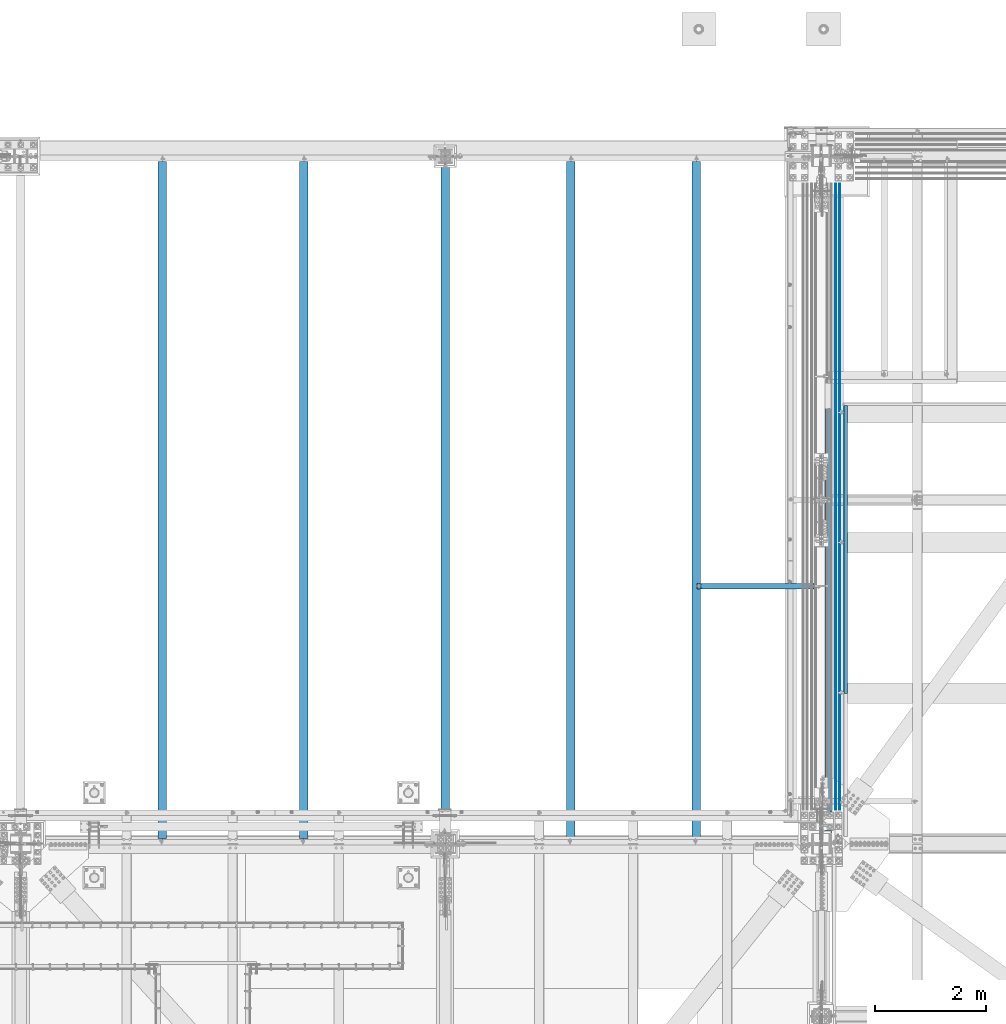
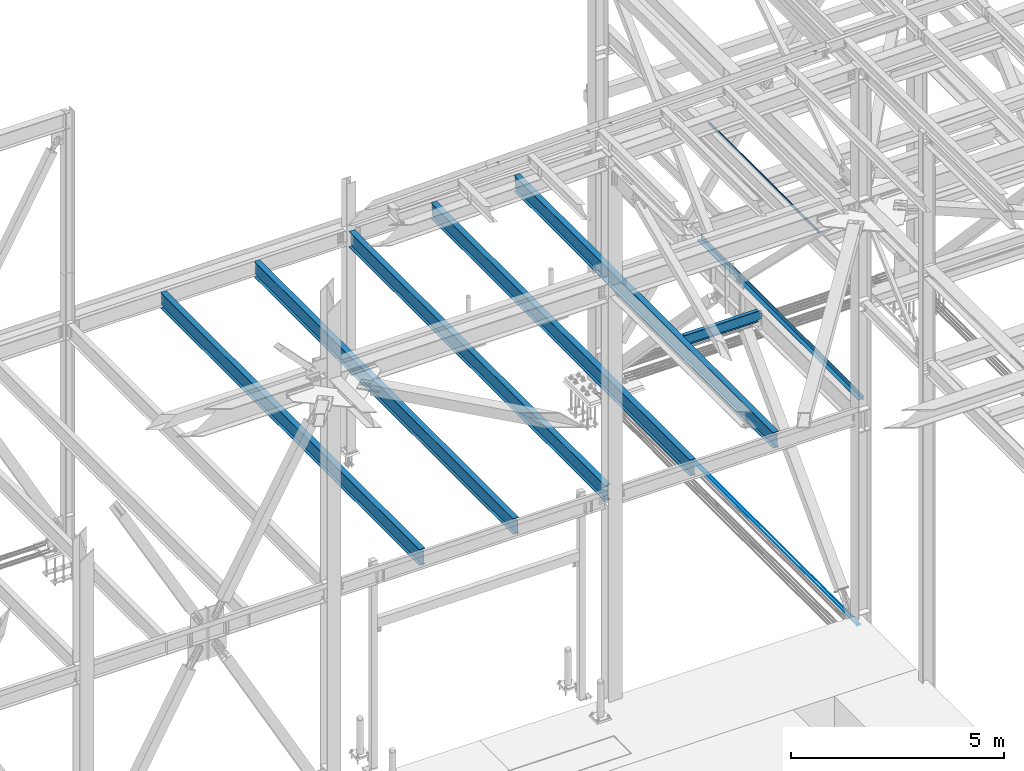
# One storey, part 1937 of 3843: 10 beams, 10 elements without a shape of their own.
"""IFC2X3 building model written with IfcOpenShell, lengths in millimetres."""

from ifc_helpers import new_model, si_unit, frame, origin_with_axes, place, context, subcontext, project, spatial, faceted_brep, material, type_object, element, aggregate, save


model = new_model("IFC2X3")

# Units and contexts
model_context = context("Model", 3, precision=1e-05, world=origin_with_axes())
body_context = subcontext(model_context, "Body", "Model", "MODEL_VIEW")
ifc_project = project(units=[si_unit("LENGTHUNIT", "METRE", prefix="MILLI"), si_unit("AREAUNIT", "SQUARE_METRE"), si_unit("VOLUMEUNIT", "CUBIC_METRE"), si_unit("MASSUNIT", "GRAM", prefix="KILO"), si_unit("TIMEUNIT", "SECOND"), si_unit("PLANEANGLEUNIT", "RADIAN"), si_unit("SOLIDANGLEUNIT", "STERADIAN"), si_unit("THERMODYNAMICTEMPERATUREUNIT", "DEGREE_CELSIUS"), si_unit("LUMINOUSINTENSITYUNIT", "LUMEN")], contexts=[model_context])

# Site, building, storey
site_placement = place(None, origin_with_axes())
site = spatial("IfcSite", under=ifc_project, at=site_placement, CompositionType="ELEMENT")
building_placement = place(site_placement, origin_with_axes())
building = spatial("IfcBuilding", under=site, at=building_placement, Name="Undefined", CompositionType="ELEMENT")
storey_placement = place(building_placement, origin_with_axes())
storey = spatial("IfcBuildingStorey", under=building, at=storey_placement, Name="Undefined", CompositionType="ELEMENT", Elevation=0.0)

# Assembly, beam
assembly_1_placement = place(storey_placement, origin_with_axes())
assembly_1 = element("IfcElementAssembly", 1, at=assembly_1_placement, inside=storey, Name="REBAR", AssemblyPlace="NOTDEFINED", PredefinedType="RIGID_FRAME")
ifc_material_1 = material(Name="STEEL/A706-60")
beam_type_1 = type_object("IfcBeamType", Name="#10 REBAR", PredefinedType="NOTDEFINED")
beam_1_placement = place(assembly_1_placement, frame((77266.8, 104063.800019533, 29700.5375), z_axis=(0.0, 0.0, 1.0), x_axis=(0.0, -1.0, 0.0)))
beam_1 = element("IfcBeam", 2, at=beam_1_placement, type_object=beam_type_1, material=ifc_material_1, Name="REBAR", ObjectType="#10 REBAR", context=body_context, shape_type="Brep", body=[
    faceted_brep([(0.0, -7.9375, 0.0), (0.0, -5.61266007566883, -5.61266007566883), (11239.5874999941, -5.61266007566883, -5.61266007566883), (11239.5874999941, -7.9375, 0.0), (0.0, 0.0, -7.9375), (11239.5874999941, 0.0, -7.9375), (0.0, 5.61266007566883, -5.61266007566883), (11239.5874999941, 5.61266007566883, -5.61266007566883), (0.0, 7.9375, 0.0), (11239.5874999941, 7.9375, 0.0), (0.0, 5.61266007566883, 5.61266007566883), (11239.5874999941, 5.61266007566883, 5.61266007566883), (0.0, 0.0, 7.9375), (11239.5874999941, 0.0, 7.9375), (0.0, -5.61266007566883, 5.61266007566883), (11239.5874999941, -5.61266007566883, 5.61266007566883)], [[[0, 1, 2, 3]], [[1, 4, 5, 2]], [[4, 6, 7, 5]], [[6, 8, 9, 7]], [[8, 10, 11, 9]], [[10, 12, 13, 11]], [[12, 14, 15, 13]], [[14, 0, 3, 15]], [[5, 7, 9, 11, 13, 15, 3, 2]], [[14, 12, 10, 8, 6, 4, 1, 0]]]),
])
aggregate(assembly_1, [beam_1])

assembly_2_placement = place(storey_placement, origin_with_axes())
assembly_2 = element("IfcElementAssembly", 3, at=assembly_2_placement, inside=storey, Name="REBAR", AssemblyPlace="NOTDEFINED", PredefinedType="RIGID_FRAME")
beam_2_placement = place(assembly_2_placement, frame((77343.0, 104063.800019533, 29700.5375), z_axis=(0.0, 0.0, 1.0), x_axis=(0.0, -1.0, 0.0)))
beam_2 = element("IfcBeam", 4, at=beam_2_placement, type_object=beam_type_1, material=ifc_material_1, Name="REBAR", ObjectType="#10 REBAR", context=body_context, shape_type="Brep", body=[
    faceted_brep([(0.0, -7.9375, 0.0), (0.0, -5.61266007566883, -5.61266007566883), (11239.5874999941, -5.61266007566883, -5.61266007566883), (11239.5874999941, -7.9375, 0.0), (0.0, 0.0, -7.9375), (11239.5874999941, 0.0, -7.9375), (0.0, 5.61266007566883, -5.61266007566883), (11239.5874999941, 5.61266007566883, -5.61266007566883), (0.0, 7.9375, 0.0), (11239.5874999941, 7.9375, 0.0), (0.0, 5.61266007566883, 5.61266007566883), (11239.5874999941, 5.61266007566883, 5.61266007566883), (0.0, 0.0, 7.9375), (11239.5874999941, 0.0, 7.9375), (0.0, -5.61266007566883, 5.61266007566883), (11239.5874999941, -5.61266007566883, 5.61266007566883)], [[[0, 1, 2, 3]], [[1, 4, 5, 2]], [[4, 6, 7, 5]], [[6, 8, 9, 7]], [[8, 10, 11, 9]], [[10, 12, 13, 11]], [[12, 14, 15, 13]], [[14, 0, 3, 15]], [[5, 7, 9, 11, 13, 15, 3, 2]], [[14, 12, 10, 8, 6, 4, 1, 0]]]),
])
aggregate(assembly_2, [beam_2])

assembly_3_placement = place(storey_placement, origin_with_axes())
assembly_3 = element("IfcElementAssembly", 5, at=assembly_3_placement, inside=storey, Name="BEAM", AssemblyPlace="NOTDEFINED", PredefinedType="RIGID_FRAME")
ifc_material_2 = material(Name="STEEL/A36")
beam_type_2 = type_object("IfcBeamType", PredefinedType="NOTDEFINED")
beam_3_placement = place(assembly_3_placement, frame((77076.3, 96218.375, 36439.475), z_axis=(0.0, -1.0, 0.0), x_axis=(1.0, 0.0, 0.0)))
beam_3 = element("IfcBeam", 6, at=beam_3_placement, type_object=beam_type_2, material=ifc_material_2, Name="BENT_PLATE", context=body_context, shape_type="Brep", body=[
    faceted_brep([(107.950003051723, -3.17500000000291, 3770.3125), (107.950003051752, 3.17500000000291, 3770.3125), (0.0, 3.17500000000291, 3770.3125), (0.0, -3.17500000000291, 3770.3125), (107.950003051737, -3.17500000000291, 3810.0), (107.950003051752, 3.17500000000291, 3810.0), (0.0, -3.17500000000291, -2149.47500215616), (0.0, 3.17500000000291, -2149.47500215616), (57.1500000000087, 3.17500000000291, -2149.47500215616), (57.1500000000087, -3.17500000000291, -2149.47500215616), (57.1500000000087, 3.17500000000291, -2187.5750021562), (57.1500000000087, -3.17500000000291, -2187.5750021562), (0.0, 3.17500000000291, -2187.5750021562), (0.0, -3.17500000000291, -2187.5750021562), (0.0, 3.17500000000291, -3810.0), (0.0, -3.17500000000291, -3810.0), (114.300003051758, -3.17500000000291, 3810.0), (114.300003051758, -3.17500000000291, -3810.0), (114.300003051758, 136.524996948239, -3810.0), (114.300003051758, 136.524996948239, 3810.0), (107.950003051752, 3.17500000000291, -3810.0), (107.950003051752, 136.524996948239, -3810.0), (107.950003051752, 136.524996948239, 3810.0)], [[[0, 1, 2, 3]], [[4, 5, 1, 0]], [[6, 7, 8, 9]], [[9, 8, 10, 11]], [[11, 10, 12, 13]], [[14, 15, 13, 12]], [[16, 17, 18, 19]], [[3, 6, 9, 11, 13, 15, 17, 16, 4, 0]], [[7, 6, 3, 2]], [[20, 14, 12, 10, 8, 7, 2, 1]], [[17, 15, 14, 20, 21, 18]], [[19, 18, 21, 22]], [[20, 1, 5, 22, 21]], [[16, 19, 22, 5, 4]]]),
])
aggregate(assembly_3, [beam_3])

assembly_4_placement = place(storey_placement, origin_with_axes())
assembly_4 = element("IfcElementAssembly", 7, at=assembly_4_placement, inside=storey, Name="BEAM", AssemblyPlace="NOTDEFINED", PredefinedType="RIGID_FRAME")
ifc_material_3 = material(Name="STEEL/A992")
beam_type_3 = type_object("IfcBeamType", Name="W12X19", PredefinedType="NOTDEFINED")
beam_4_placement = place(assembly_4_placement, frame((74760.534374, 96837.5, 36282.3125), z_axis=(0.0, 0.0, 1.0), x_axis=(1.0, 0.0, 0.0)))
beam_4 = element("IfcBeam", 8, at=beam_4_placement, type_object=beam_type_3, material=ifc_material_3, Name="BEAM", ObjectType="W12X19", context=body_context, shape_type="Brep", body=[
    faceted_brep([(80.1687501907145, -3.17500000000018, 128.587499999994), (80.1687501907145, 3.17500000000018, 128.587499999994), (16.6687499999971, 3.17499999999927, 128.587500000001), (16.6687499999971, -3.17499999999927, 128.587500000001), (85.0288297087536, -3.17500000000018, 129.554229922585), (85.0288297087536, 3.17500000000018, 129.554229922585), (89.1490061769146, -3.17500000000018, 132.307243823059), (89.1490061769146, 3.17500000000018, 132.307243823059), (91.9020200773957, -3.17500000000018, 136.427420291213), (91.9020200773957, 3.17500000000018, 136.427420291213), (92.8687499999796, -3.17500000000018, 141.287499809259), (92.8687499999796, 3.17500000000018, 141.287499809259), (92.8687499999796, -50.8000000000002, 153.987499810319), (92.8687499999796, 50.8000000000002, 153.987500000003), (92.8687499999796, 50.8000000000002, 144.462500000001), (92.8687499999796, 3.17500000000018, 144.462500000001), (92.8687499999796, -3.17500000000018, 144.462500000001), (92.8687499999796, -50.8000000000002, 144.462500000001), (16.6687499999971, -3.17499999999927, -144.462500000001), (16.6687499999971, -50.7999999999993, -144.462500000001), (2118.12187599999, -50.8000000000029, -144.462500000001), (2118.12187599999, -3.17500000000291, -144.462500000001), (16.6687499999971, -50.7999999999993, -153.987500000003), (2118.12187599999, -50.8000000000029, -153.987500000003), (16.6687499999971, 50.7999999999993, -153.987500000003), (2118.12187599999, 50.8000000000029, -153.987500000003), (16.6687499999971, 50.7999999999993, -144.462500000001), (2118.12187599999, 50.8000000000029, -144.462500000001), (16.6687499999971, 3.17499999999927, -144.462500000001), (2118.12187599999, 3.17500000000291, -144.462500000001), (2118.12187599999, 3.17500000000291, -141.287499809267), (2118.12187599999, -3.17500000000291, -141.287499809267), (2119.08860592257, 3.17500000000291, -136.42742029122), (2119.08860592257, -3.17500000000291, -136.42742029122), (2121.84161982306, 3.17500000000291, -132.307243823067), (2121.84161982306, -3.17500000000291, -132.307243823067), (2125.96179629122, 3.17500000000291, -129.554229922593), (2125.96179629122, -3.17500000000291, -129.554229922593), (2130.82187580926, 3.17500000000291, -128.587500000001), (2130.82187580926, -3.17500000000291, -128.587500000001), (2232.42187599999, -3.17500000000291, -128.587500000001), (2232.42187599999, 3.17500000000291, -128.587500000001), (2232.42187599999, 3.17500000000291, 115.887499999997), (2232.42187599999, -3.17500000000291, 115.887499999997), (2130.82187580926, 3.17500000000291, 115.887499999997), (2130.82187580926, -3.17500000000291, 115.887499999997), (2125.96179629122, 3.17500000000291, 116.854229922588), (2125.96179629122, -3.17500000000291, 116.854229922588), (2121.84161982306, 3.17500000000291, 119.607243823062), (2121.84161982306, -3.17500000000291, 119.607243823062), (2119.08860592257, 3.17500000000291, 123.727420291216), (2119.08860592257, -3.17500000000291, 123.727420291216), (2118.12187599999, 3.17500000000291, 128.587499809262), (2118.12187599999, -3.17500000000291, 128.587499809262), (2118.12187599999, -50.8000000000029, 153.987500000003), (2118.12187599999, -50.8000000000029, 144.462500000001), (2118.12187599999, -3.17500000000291, 144.462500000001), (2118.12187599999, 3.17500000000291, 144.462500000001), (2118.12187599999, 50.8000000000029, 144.462500000001), (2118.12187599999, 50.8000000000029, 153.987500000003), (16.6687499999971, 3.17499999999927, 115.887499999742), (16.6687499999971, 3.17499999999927, -114.712500000256)], [[[0, 1, 2, 3]], [[4, 5, 1, 0]], [[6, 7, 5, 4]], [[8, 9, 7, 6]], [[10, 11, 9, 8]], [[12, 13, 14, 15, 11, 10, 16, 17]], [[18, 19, 20, 21]], [[19, 22, 23, 20]], [[22, 24, 25, 23]], [[24, 26, 27, 25]], [[26, 28, 29, 27]], [[21, 20, 23, 25, 27, 29, 30, 31]], [[31, 30, 32, 33]], [[33, 32, 34, 35]], [[35, 34, 36, 37]], [[37, 36, 38, 39]], [[40, 39, 38, 41]], [[40, 41, 42, 43]], [[43, 42, 44, 45]], [[45, 44, 46, 47]], [[47, 46, 48, 49]], [[49, 48, 50, 51]], [[51, 50, 52, 53]], [[54, 55, 56, 53, 52, 57, 58, 59]], [[55, 54, 12, 17]], [[56, 55, 17, 16]], [[8, 6, 4, 0, 3, 18, 21, 31, 33, 35, 37, 39, 40, 43, 45, 47, 49, 51, 53, 56, 16, 10]], [[60, 61, 28, 26, 24, 22, 19, 18, 3, 2]], [[57, 52, 50, 48, 46, 44, 42, 41, 38, 36, 34, 32, 30, 29, 28, 61, 60, 2, 1, 5, 7, 9, 11, 15]], [[58, 57, 15, 14]], [[59, 58, 14, 13]], [[54, 59, 13, 12]]]),
])
aggregate(assembly_4, [beam_4])

assembly_5_placement = place(storey_placement, origin_with_axes())
assembly_5 = element("IfcElementAssembly", 9, at=assembly_5_placement, inside=storey, Name="BENT_PLATE", AssemblyPlace="NOTDEFINED", PredefinedType="RIGID_FRAME")
beam_type_4 = type_object("IfcBeamType", PredefinedType="NOTDEFINED")
beam_5_placement = place(assembly_5_placement, frame((77484.2872499992, 97499.090384, 39627.1750000002), z_axis=(0.0, 1.0, 0.0), x_axis=(-1.0, 0.0, 0.0)))
beam_5 = element("IfcBeam", 10, at=beam_5_placement, type_object=beam_type_4, material=ifc_material_2, Name="BENT_PLATE", context=body_context, shape_type="Brep", body=[
    faceted_brep([(0.0, -3.17500000000291, -2583.6565), (0.0, -3.17500000000291, 2583.6565), (0.0, 3.17500000000291, 2583.6565), (0.0, 3.17500000000291, -2583.6565), (69.8499999995256, 3.17500000000291, 2583.6565), (69.8499999995256, 3.17500000000291, -2583.6565), (76.1999999995169, -3.17500000000291, -2583.6565), (76.1999999995169, -3.17500000000291, 2583.6565), (69.8499999995984, 73.0250000004962, 2583.6565), (69.8499999995984, 73.0250000004962, -2583.6565), (76.1999999996042, 73.0250000004817, 2583.6565), (76.1999999996042, 73.0250000004817, -2583.6565)], [[[0, 1, 2, 3]], [[3, 2, 4, 5]], [[1, 0, 6, 7]], [[5, 4, 8, 9]], [[4, 2, 1, 7, 10, 8]], [[7, 6, 11, 10]], [[6, 0, 3, 5, 9, 11]], [[10, 11, 9, 8]]]),
])
aggregate(assembly_5, [beam_5])

assembly_6_placement = place(storey_placement, origin_with_axes())
assembly_6 = element("IfcElementAssembly", 11, at=assembly_6_placement, inside=storey, Name="BEAM", AssemblyPlace="NOTDEFINED", PredefinedType="RIGID_FRAME")
beam_type_5 = type_object("IfcBeamType", Name="W18X40", PredefinedType="NOTDEFINED")
beam_6_placement = place(assembly_6_placement, frame((74760.534374, 92214.7, 36209.2875), z_axis=(0.0, 0.0, 1.0), x_axis=(0.0, 1.0, 0.0)))
beam_6 = element("IfcBeam", 12, at=beam_6_placement, type_object=beam_type_5, material=ifc_material_3, Name="BEAM", ObjectType="W18X40", context=body_context, shape_type="Brep", body=[
    faceted_brep([(16.6687499999971, -3.96875, -201.612500000003), (16.6687499999971, 3.96875, -201.612500000003), (80.1687501907145, 3.96875, -201.612500000003), (80.1687501907145, -3.96875, -201.612500000003), (85.0288297087536, 3.96875, -202.579229922594), (85.0288297087536, -3.96875, -202.579229922594), (89.1490061769146, 3.96875, -205.332243823068), (89.1490061769146, -3.96875, -205.332243823068), (91.9020200773957, 3.96875, -209.452420291222), (91.9020200773957, -3.96875, -209.452420291222), (92.8687499999796, 3.96875, -214.3125), (92.8687499999796, -3.96875, -214.3125), (92.8687499999796, -76.1999999999971, -214.312499809268), (92.8687499999796, 76.1999999999971, -214.3125), (92.8687499999796, 76.1999999999971, -227.012499999997), (92.8687499999796, -76.1999999999971, -227.012499809534), (12251.53125, -76.1999999999971, -227.012499999997), (12251.53125, 76.1999999999971, -227.012499999997), (12251.53125, 76.1999999999971, -214.57249980927), (12251.53125, -76.1999999999971, -214.57249980927), (12251.53125, 76.1999999999971, 214.3125), (12251.53125, 3.96875, 214.3125), (92.8687499999942, 3.96875, 214.3125), (92.8687499999942, 76.1999999999971, 214.3125), (80.168750190729, -3.96875, 201.612499999996), (80.168750190729, 3.96875, 201.612499999996), (16.6687499999971, 3.96875, 201.612499999996), (16.6687499999971, -3.96875, 201.612499999996), (85.0288297087682, -3.96875, 202.579229922587), (85.0288297087682, 3.96875, 202.579229922587), (89.1490061769291, -3.96875, 205.332243823061), (89.1490061769291, 3.96875, 205.332243823061), (91.9020200774103, -3.96875, 209.452420291214), (91.9020200774103, 3.96875, 209.452420291214), (92.8687499999942, -3.96875, 214.3125), (12251.53125, -76.1999999999971, 227.012499999997), (12251.53125, 76.1999999999971, 227.012499999997), (92.8687499999942, 76.1999999999971, 227.012499999997), (92.8687499999942, -76.1999999999971, 227.01249980952), (12251.53125, -76.1999999999971, 214.3125), (92.8687499999942, -76.1999999999971, 214.3125), (12251.53125, -3.96875, 214.3125), (12251.53125, -3.96875, 214.052501487728), (12251.53125, 3.96875, 214.052501487728), (12252.4979799226, -3.96875, 209.192421969681), (12252.4979799226, 3.96875, 209.192421969681), (12255.2509938231, -3.96875, 205.072245501528), (12255.2509938231, 3.96875, 205.072245501528), (12259.3711702912, -3.96875, 202.319231601054), (12259.3711702912, 3.96875, 202.319231601054), (12264.2312498093, -3.96875, 201.352501678462), (12264.2312498093, 3.96875, 201.352501678462), (12327.73125, -3.96875, 201.352499999994), (12327.73125, 3.96875, 201.352499999994), (12327.73125, -3.96875, -201.872500000005), (12327.73125, 3.96875, -201.872500000005), (12264.2312498093, -3.96875, -201.872500000005), (12264.2312498093, 3.96875, -201.872500000005), (12259.3711702912, -3.96875, -202.839229922596), (12259.3711702912, 3.96875, -202.839229922596), (12255.2509938231, -3.96875, -205.59224382307), (12255.2509938231, 3.96875, -205.59224382307), (12252.4979799226, -3.96875, -209.712420291224), (12252.4979799226, 3.96875, -209.712420291224), (12251.5829671776, -3.96875, -214.3125), (12251.5829671776, -76.1999999999971, -214.3125), (12251.5829671776, 76.1999999999971, -214.3125), (12251.5829671776, 3.96875, -214.3125), (16.6687499999971, 3.96875, -117.887499999997), (16.6687499999971, 3.96875, 188.912499999999)], [[[0, 1, 2, 3]], [[3, 2, 4, 5]], [[5, 4, 6, 7]], [[7, 6, 8, 9]], [[9, 8, 10, 11]], [[12, 11, 10, 13, 14, 15]], [[16, 17, 18, 19]], [[20, 21, 22, 23]], [[24, 25, 26, 27]], [[28, 29, 25, 24]], [[30, 31, 29, 28]], [[32, 33, 31, 30]], [[34, 22, 33, 32]], [[35, 36, 37, 38]], [[39, 35, 38, 40]], [[41, 39, 40, 34]], [[38, 37, 23, 22, 34, 40]], [[36, 20, 23, 37]], [[35, 39, 41, 42, 43, 21, 20, 36]], [[44, 45, 43, 42]], [[46, 47, 45, 44]], [[48, 49, 47, 46]], [[50, 51, 49, 48]], [[52, 53, 51, 50]], [[53, 52, 54, 55]], [[54, 56, 57, 55]], [[58, 59, 57, 56]], [[60, 61, 59, 58]], [[62, 63, 61, 60]], [[64, 65, 19, 18, 66, 67, 63, 62]], [[16, 19, 65, 12, 15]], [[17, 16, 15, 14]], [[66, 18, 17, 14, 13]], [[67, 66, 13, 10]], [[6, 4, 2, 1, 68, 69, 26, 25, 29, 31, 33, 22, 21, 43, 45, 47, 49, 51, 53, 55, 57, 59, 61, 63, 67, 10, 8]], [[27, 26, 69, 68, 1, 0]], [[64, 62, 60, 58, 56, 54, 52, 50, 48, 46, 44, 42, 41, 34, 32, 30, 28, 24, 27, 0, 3, 5, 7, 9, 11]], [[65, 64, 11, 12]]]),
])
aggregate(assembly_6, [beam_6])

assembly_7_placement = place(storey_placement, origin_with_axes())
assembly_7 = element("IfcElementAssembly", 13, at=assembly_7_placement, inside=storey, Name="BEAM", AssemblyPlace="NOTDEFINED", PredefinedType="RIGID_FRAME")
beam_7_placement = place(assembly_7_placement, frame((72508.467187, 92214.7, 36209.2875), z_axis=(0.0, 0.0, 1.0), x_axis=(0.0, 1.0, 0.0)))
beam_7 = element("IfcBeam", 14, at=beam_7_placement, type_object=beam_type_5, material=ifc_material_3, Name="BEAM", ObjectType="W18X40", context=body_context, shape_type="Brep", body=[
    faceted_brep([(16.6687499999971, -3.96875, -201.612500000003), (16.6687499999971, 3.96875, -201.612500000003), (80.1687501907145, 3.96875, -201.612500000003), (80.1687501907145, -3.96875, -201.612500000003), (85.0288297087536, 3.96875, -202.579229922594), (85.0288297087536, -3.96875, -202.579229922594), (89.1490061769146, 3.96875, -205.332243823068), (89.1490061769146, -3.96875, -205.332243823068), (91.9020200773957, 3.96875, -209.452420291222), (91.9020200773957, -3.96875, -209.452420291222), (92.8687499999796, 3.96875, -214.3125), (92.8687499999796, -3.96875, -214.3125), (92.8687499999796, -76.1999999999971, -214.312499809268), (92.8687499999796, 76.1999999999971, -214.3125), (92.8687499999796, 76.1999999999971, -227.012499999997), (92.8687499999796, -76.1999999999971, -227.012499809534), (12251.53125, -76.1999999999971, -227.012499999997), (12251.53125, 76.1999999999971, -227.012499999997), (12251.53125, 76.1999999999971, -214.57249980927), (12251.53125, -76.1999999999971, -214.57249980927), (12251.53125, 76.1999999999971, 214.3125), (12251.53125, 3.96875, 214.3125), (92.8687499999942, 3.96875, 214.3125), (92.8687499999942, 76.1999999999971, 214.3125), (80.168750190729, -3.96875, 201.612499999996), (80.168750190729, 3.96875, 201.612499999996), (16.6687499999971, 3.96875, 201.612499999996), (16.6687499999971, -3.96875, 201.612499999996), (85.0288297087682, -3.96875, 202.579229922587), (85.0288297087682, 3.96875, 202.579229922587), (89.1490061769291, -3.96875, 205.332243823061), (89.1490061769291, 3.96875, 205.332243823061), (91.9020200774103, -3.96875, 209.452420291214), (91.9020200774103, 3.96875, 209.452420291214), (92.8687499999942, -3.96875, 214.3125), (12251.53125, -76.1999999999971, 227.012499999997), (12251.53125, 76.1999999999971, 227.012499999997), (92.8687499999942, 76.1999999999971, 227.012499999997), (92.8687499999942, -76.1999999999971, 227.01249980952), (12251.53125, -76.1999999999971, 214.3125), (92.8687499999942, -76.1999999999971, 214.3125), (12251.53125, -3.96875, 214.3125), (12251.53125, -3.96875, 214.052501487728), (12251.53125, 3.96875, 214.052501487728), (12252.4979799226, -3.96875, 209.192421969681), (12252.4979799226, 3.96875, 209.192421969681), (12255.2509938231, -3.96875, 205.072245501528), (12255.2509938231, 3.96875, 205.072245501528), (12259.3711702912, -3.96875, 202.319231601054), (12259.3711702912, 3.96875, 202.319231601054), (12264.2312498093, -3.96875, 201.352501678462), (12264.2312498093, 3.96875, 201.352501678462), (12327.73125, -3.96875, 201.352499999994), (12327.73125, 3.96875, 201.352499999994), (12327.73125, -3.96875, -201.872500000005), (12327.73125, 3.96875, -201.872500000005), (12264.2312498093, -3.96875, -201.872500000005), (12264.2312498093, 3.96875, -201.872500000005), (12259.3711702912, -3.96875, -202.839229922596), (12259.3711702912, 3.96875, -202.839229922596), (12255.2509938231, -3.96875, -205.59224382307), (12255.2509938231, 3.96875, -205.59224382307), (12252.4979799226, -3.96875, -209.712420291224), (12252.4979799226, 3.96875, -209.712420291224), (12251.5829671776, -3.96875, -214.3125), (12251.5829671776, -76.1999999999971, -214.3125), (12251.5829671776, 76.1999999999971, -214.3125), (12251.5829671776, 3.96875, -214.3125), (16.6687499999971, 3.96875, -117.887499999997), (16.6687499999971, 3.96875, 188.912499999999)], [[[0, 1, 2, 3]], [[3, 2, 4, 5]], [[5, 4, 6, 7]], [[7, 6, 8, 9]], [[9, 8, 10, 11]], [[12, 11, 10, 13, 14, 15]], [[16, 17, 18, 19]], [[20, 21, 22, 23]], [[24, 25, 26, 27]], [[28, 29, 25, 24]], [[30, 31, 29, 28]], [[32, 33, 31, 30]], [[34, 22, 33, 32]], [[35, 36, 37, 38]], [[39, 35, 38, 40]], [[41, 39, 40, 34]], [[38, 37, 23, 22, 34, 40]], [[36, 20, 23, 37]], [[35, 39, 41, 42, 43, 21, 20, 36]], [[44, 45, 43, 42]], [[46, 47, 45, 44]], [[48, 49, 47, 46]], [[50, 51, 49, 48]], [[52, 53, 51, 50]], [[53, 52, 54, 55]], [[54, 56, 57, 55]], [[58, 59, 57, 56]], [[60, 61, 59, 58]], [[62, 63, 61, 60]], [[64, 65, 19, 18, 66, 67, 63, 62]], [[16, 19, 65, 12, 15]], [[17, 16, 15, 14]], [[66, 18, 17, 14, 13]], [[67, 66, 13, 10]], [[6, 4, 2, 1, 68, 69, 26, 25, 29, 31, 33, 22, 21, 43, 45, 47, 49, 51, 53, 55, 57, 59, 61, 63, 67, 10, 8]], [[27, 26, 69, 68, 1, 0]], [[64, 62, 60, 58, 56, 54, 52, 50, 48, 46, 44, 42, 41, 34, 32, 30, 28, 24, 27, 0, 3, 5, 7, 9, 11]], [[65, 64, 11, 12]]]),
])
aggregate(assembly_7, [beam_7])

assembly_8_placement = place(storey_placement, origin_with_axes())
assembly_8 = element("IfcElementAssembly", 15, at=assembly_8_placement, inside=storey, Name="BEAM", AssemblyPlace="NOTDEFINED", PredefinedType="RIGID_FRAME")
beam_8_placement = place(assembly_8_placement, frame((67716.4, 92214.7, 36209.2875), z_axis=(0.0, 0.0, 1.0), x_axis=(0.0, 1.0, 0.0)))
beam_8 = element("IfcBeam", 16, at=beam_8_placement, type_object=beam_type_5, material=ifc_material_3, Name="BEAM", ObjectType="W18X40", context=body_context, shape_type="Brep", body=[
    faceted_brep([(16.6687499999971, -3.96875, -201.612500000003), (16.6687499999971, 3.96875, -201.612500000003), (80.1687501907145, 3.96875, -201.612500000003), (80.1687501907145, -3.96875, -201.612500000003), (85.0288297087536, 3.96875, -202.579229922594), (85.0288297087536, -3.96875, -202.579229922594), (89.1490061769146, 3.96875, -205.332243823068), (89.1490061769146, -3.96875, -205.332243823068), (91.9020200773957, 3.96875, -209.452420291222), (91.9020200773957, -3.96875, -209.452420291222), (92.8687499999796, 3.96875, -214.3125), (92.8687499999796, -3.96875, -214.3125), (92.8687499999796, -76.1999999999971, -214.312499809268), (92.8687499999796, 76.1999999999971, -214.3125), (92.8687499999796, 76.1999999999971, -227.012499999997), (92.8687499999796, -76.1999999999971, -227.012499809534), (12251.53125, -76.1999999999971, -227.012499999997), (12251.53125, 76.1999999999971, -227.012499999997), (12251.53125, 76.1999999999971, -214.57249980927), (12251.53125, -76.1999999999971, -214.57249980927), (12251.53125, 76.1999999999971, 214.3125), (12251.53125, 3.96875, 214.3125), (92.8687499999942, 3.96875, 214.3125), (92.8687499999942, 76.1999999999971, 214.3125), (80.168750190729, -3.96875, 201.612499999996), (80.168750190729, 3.96875, 201.612499999996), (16.6687499999971, 3.96875, 201.612499999996), (16.6687499999971, -3.96875, 201.612499999996), (85.0288297087682, -3.96875, 202.579229922587), (85.0288297087682, 3.96875, 202.579229922587), (89.1490061769291, -3.96875, 205.332243823061), (89.1490061769291, 3.96875, 205.332243823061), (91.9020200774103, -3.96875, 209.452420291214), (91.9020200774103, 3.96875, 209.452420291214), (92.8687499999942, -3.96875, 214.3125), (12251.53125, -76.1999999999971, 227.012499999997), (12251.53125, 76.1999999999971, 227.012499999997), (92.8687499999942, 76.1999999999971, 227.012499999997), (92.8687499999942, -76.1999999999971, 227.01249980952), (12251.53125, -76.1999999999971, 214.3125), (92.8687499999942, -76.1999999999971, 214.3125), (12251.53125, -3.96875, 214.3125), (12251.53125, -3.96875, 214.052501487728), (12251.53125, 3.96875, 214.052501487728), (12252.4979799226, -3.96875, 209.192421969681), (12252.4979799226, 3.96875, 209.192421969681), (12255.2509938231, -3.96875, 205.072245501528), (12255.2509938231, 3.96875, 205.072245501528), (12259.3711702912, -3.96875, 202.319231601054), (12259.3711702912, 3.96875, 202.319231601054), (12264.2312498093, -3.96875, 201.352501678462), (12264.2312498093, 3.96875, 201.352501678462), (12327.73125, -3.96875, 201.352499999994), (12327.73125, 3.96875, 201.352499999994), (12327.73125, -3.96875, -201.872500000005), (12327.73125, 3.96875, -201.872500000005), (12264.2312498093, -3.96875, -201.872500000005), (12264.2312498093, 3.96875, -201.872500000005), (12259.3711702912, -3.96875, -202.839229922596), (12259.3711702912, 3.96875, -202.839229922596), (12255.2509938231, -3.96875, -205.59224382307), (12255.2509938231, 3.96875, -205.59224382307), (12252.4979799226, -3.96875, -209.712420291224), (12252.4979799226, 3.96875, -209.712420291224), (12251.5829671776, -3.96875, -214.3125), (12251.5829671776, -76.1999999999971, -214.3125), (12251.5829671776, 76.1999999999971, -214.3125), (12251.5829671776, 3.96875, -214.3125), (16.6687499999971, 3.96875, -117.887499999997), (16.6687499999971, 3.96875, 188.912499999999)], [[[0, 1, 2, 3]], [[3, 2, 4, 5]], [[5, 4, 6, 7]], [[7, 6, 8, 9]], [[9, 8, 10, 11]], [[12, 11, 10, 13, 14, 15]], [[16, 17, 18, 19]], [[20, 21, 22, 23]], [[24, 25, 26, 27]], [[28, 29, 25, 24]], [[30, 31, 29, 28]], [[32, 33, 31, 30]], [[34, 22, 33, 32]], [[35, 36, 37, 38]], [[39, 35, 38, 40]], [[41, 39, 40, 34]], [[38, 37, 23, 22, 34, 40]], [[36, 20, 23, 37]], [[35, 39, 41, 42, 43, 21, 20, 36]], [[44, 45, 43, 42]], [[46, 47, 45, 44]], [[48, 49, 47, 46]], [[50, 51, 49, 48]], [[52, 53, 51, 50]], [[53, 52, 54, 55]], [[54, 56, 57, 55]], [[58, 59, 57, 56]], [[60, 61, 59, 58]], [[62, 63, 61, 60]], [[64, 65, 19, 18, 66, 67, 63, 62]], [[16, 19, 65, 12, 15]], [[17, 16, 15, 14]], [[66, 18, 17, 14, 13]], [[67, 66, 13, 10]], [[6, 4, 2, 1, 68, 69, 26, 25, 29, 31, 33, 22, 21, 43, 45, 47, 49, 51, 53, 55, 57, 59, 61, 63, 67, 10, 8]], [[27, 26, 69, 68, 1, 0]], [[64, 62, 60, 58, 56, 54, 52, 50, 48, 46, 44, 42, 41, 34, 32, 30, 28, 24, 27, 0, 3, 5, 7, 9, 11]], [[65, 64, 11, 12]]]),
])
aggregate(assembly_8, [beam_8])

assembly_9_placement = place(storey_placement, origin_with_axes())
assembly_9 = element("IfcElementAssembly", 17, at=assembly_9_placement, inside=storey, Name="BEAM", AssemblyPlace="NOTDEFINED", PredefinedType="RIGID_FRAME")
beam_9_placement = place(assembly_9_placement, frame((65176.4, 92214.7, 36209.2875), z_axis=(0.0, 0.0, 1.0), x_axis=(0.0, 1.0, 0.0)))
beam_9 = element("IfcBeam", 18, at=beam_9_placement, type_object=beam_type_5, material=ifc_material_3, Name="BEAM", ObjectType="W18X40", context=body_context, shape_type="Brep", body=[
    faceted_brep([(16.6687499999971, -3.96875, -201.612500000003), (16.6687499999971, 3.96875, -201.612500000003), (80.1687501907145, 3.96875, -201.612500000003), (80.1687501907145, -3.96875, -201.612500000003), (85.0288297087536, 3.96875, -202.579229922594), (85.0288297087536, -3.96875, -202.579229922594), (89.1490061769146, 3.96875, -205.332243823068), (89.1490061769146, -3.96875, -205.332243823068), (91.9020200773957, 3.96875, -209.452420291222), (91.9020200773957, -3.96875, -209.452420291222), (92.8687499999796, 3.96875, -214.3125), (92.8687499999796, -3.96875, -214.3125), (92.8687499999796, -76.1999999999971, -214.312499809268), (92.8687499999796, 76.1999999999971, -214.3125), (92.8687499999796, 76.1999999999971, -227.012499999997), (92.8687499999796, -76.1999999999971, -227.012499809534), (12251.53125, -76.1999999999971, -227.012499999997), (12251.53125, 76.1999999999971, -227.012499999997), (12251.53125, 76.1999999999971, -214.57249980927), (12251.53125, -76.1999999999971, -214.57249980927), (12251.53125, 76.1999999999971, 214.3125), (12251.53125, 3.96875, 214.3125), (92.8687499999942, 3.96875, 214.3125), (92.8687499999942, 76.1999999999971, 214.3125), (80.168750190729, -3.96875, 201.612499999996), (80.168750190729, 3.96875, 201.612499999996), (16.6687499999971, 3.96875, 201.612499999996), (16.6687499999971, -3.96875, 201.612499999996), (85.0288297087682, -3.96875, 202.579229922587), (85.0288297087682, 3.96875, 202.579229922587), (89.1490061769291, -3.96875, 205.332243823061), (89.1490061769291, 3.96875, 205.332243823061), (91.9020200774103, -3.96875, 209.452420291214), (91.9020200774103, 3.96875, 209.452420291214), (92.8687499999942, -3.96875, 214.3125), (12251.53125, -76.1999999999971, 227.012499999997), (12251.53125, 76.1999999999971, 227.012499999997), (92.8687499999942, 76.1999999999971, 227.012499999997), (92.8687499999942, -76.1999999999971, 227.01249980952), (12251.53125, -76.1999999999971, 214.3125), (92.8687499999942, -76.1999999999971, 214.3125), (12251.53125, -3.96875, 214.3125), (12251.53125, -3.96875, 214.052501487728), (12251.53125, 3.96875, 214.052501487728), (12252.4979799226, -3.96875, 209.192421969681), (12252.4979799226, 3.96875, 209.192421969681), (12255.2509938231, -3.96875, 205.072245501528), (12255.2509938231, 3.96875, 205.072245501528), (12259.3711702912, -3.96875, 202.319231601054), (12259.3711702912, 3.96875, 202.319231601054), (12264.2312498093, -3.96875, 201.352501678462), (12264.2312498093, 3.96875, 201.352501678462), (12327.73125, -3.96875, 201.352499999994), (12327.73125, 3.96875, 201.352499999994), (12327.73125, -3.96875, -201.872500000005), (12327.73125, 3.96875, -201.872500000005), (12264.2312498093, -3.96875, -201.872500000005), (12264.2312498093, 3.96875, -201.872500000005), (12259.3711702912, -3.96875, -202.839229922596), (12259.3711702912, 3.96875, -202.839229922596), (12255.2509938231, -3.96875, -205.59224382307), (12255.2509938231, 3.96875, -205.59224382307), (12252.4979799226, -3.96875, -209.712420291224), (12252.4979799226, 3.96875, -209.712420291224), (12251.5829671776, -3.96875, -214.3125), (12251.5829671776, -76.1999999999971, -214.3125), (12251.5829671776, 76.1999999999971, -214.3125), (12251.5829671776, 3.96875, -214.3125), (16.6687499999971, 3.96875, -117.887499999997), (16.6687499999971, 3.96875, 188.912499999999)], [[[0, 1, 2, 3]], [[3, 2, 4, 5]], [[5, 4, 6, 7]], [[7, 6, 8, 9]], [[9, 8, 10, 11]], [[12, 11, 10, 13, 14, 15]], [[16, 17, 18, 19]], [[20, 21, 22, 23]], [[24, 25, 26, 27]], [[28, 29, 25, 24]], [[30, 31, 29, 28]], [[32, 33, 31, 30]], [[34, 22, 33, 32]], [[35, 36, 37, 38]], [[39, 35, 38, 40]], [[41, 39, 40, 34]], [[38, 37, 23, 22, 34, 40]], [[36, 20, 23, 37]], [[35, 39, 41, 42, 43, 21, 20, 36]], [[44, 45, 43, 42]], [[46, 47, 45, 44]], [[48, 49, 47, 46]], [[50, 51, 49, 48]], [[52, 53, 51, 50]], [[53, 52, 54, 55]], [[54, 56, 57, 55]], [[58, 59, 57, 56]], [[60, 61, 59, 58]], [[62, 63, 61, 60]], [[64, 65, 19, 18, 66, 67, 63, 62]], [[16, 19, 65, 12, 15]], [[17, 16, 15, 14]], [[66, 18, 17, 14, 13]], [[67, 66, 13, 10]], [[6, 4, 2, 1, 68, 69, 26, 25, 29, 31, 33, 22, 21, 43, 45, 47, 49, 51, 53, 55, 57, 59, 61, 63, 67, 10, 8]], [[27, 26, 69, 68, 1, 0]], [[64, 62, 60, 58, 56, 54, 52, 50, 48, 46, 44, 42, 41, 34, 32, 30, 28, 24, 27, 0, 3, 5, 7, 9, 11]], [[65, 64, 11, 12]]]),
])
aggregate(assembly_9, [beam_9])

assembly_10_placement = place(storey_placement, origin_with_axes())
assembly_10 = element("IfcElementAssembly", 19, at=assembly_10_placement, inside=storey, Name="BEAM", AssemblyPlace="NOTDEFINED", PredefinedType="RIGID_FRAME")
beam_10_placement = place(assembly_10_placement, frame((70256.4, 92214.7, 36209.2875), z_axis=(0.0, 0.0, 1.0), x_axis=(0.0, 1.0, 0.0)))
beam_10 = element("IfcBeam", 20, at=beam_10_placement, type_object=beam_type_5, material=ifc_material_3, Name="BEAM", ObjectType="W18X40", context=body_context, shape_type="Brep", body=[
    faceted_brep([(190.5, -76.1999999999971, -227.012499999997), (190.5, 76.1999999999971, -227.012499999997), (12204.7, 76.1999999999998, -227.012499999997), (12204.7, -76.1999999999998, -227.012499999997), (190.5, -76.1999999999971, -214.3125), (190.5, -3.96875, -214.3125), (190.5, -3.96875, 214.3125), (190.5, -76.1999999999971, 214.3125), (190.5, -76.1999999999971, 227.012499999997), (190.5, 76.1999999999971, 227.012499999997), (190.5, 76.1999999999971, 214.3125), (190.5, 3.96875, 214.3125), (190.5, 3.96875, -214.3125), (190.5, 76.1999999999971, -214.3125), (12204.7, -76.1999999999998, -214.3125), (12204.7, -3.96875, -214.3125), (12204.7, -3.96875, 214.3125), (12204.7, -76.1999999999998, 214.3125), (12204.7, -76.1999999999998, 227.012499999997), (12204.7, 76.1999999999998, 227.012499999997), (12204.7, 76.1999999999998, 214.3125), (12204.7, 3.96875, 214.3125), (12204.7, 3.96875, -214.3125), (12204.7, 76.1999999999998, -214.3125)], [[[0, 1, 2, 3]], [[0, 4, 5, 6, 7, 8, 9, 10, 11, 12, 13, 1]], [[5, 4, 14, 15]], [[6, 5, 15, 16]], [[7, 6, 16, 17]], [[8, 7, 17, 18]], [[9, 8, 18, 19]], [[10, 9, 19, 20]], [[11, 10, 20, 21]], [[12, 11, 21, 22]], [[13, 12, 22, 23]], [[1, 13, 23, 2]], [[22, 21, 20, 19, 18, 17, 16, 15, 14, 3, 2, 23]], [[4, 0, 3, 14]]]),
])
aggregate(assembly_10, [beam_10])

save(model, "model.ifc")
